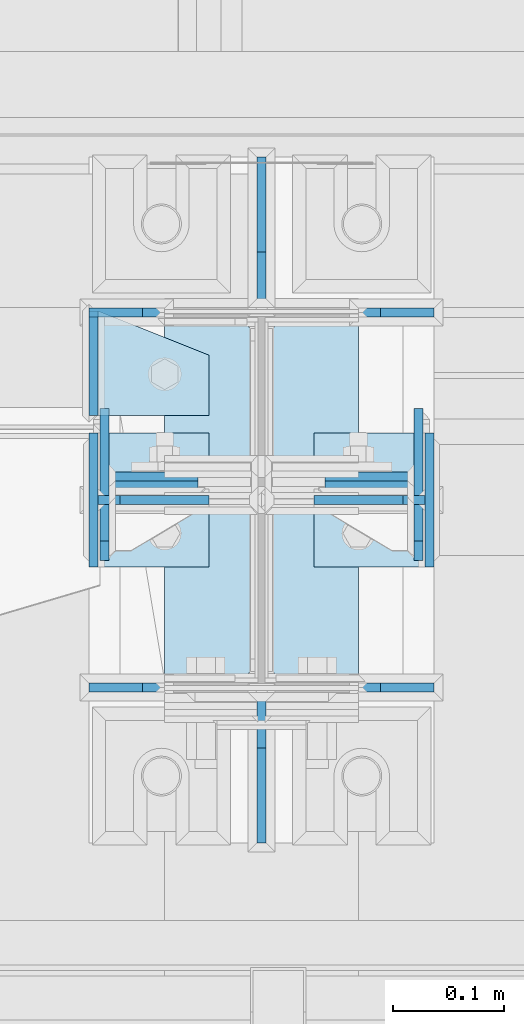
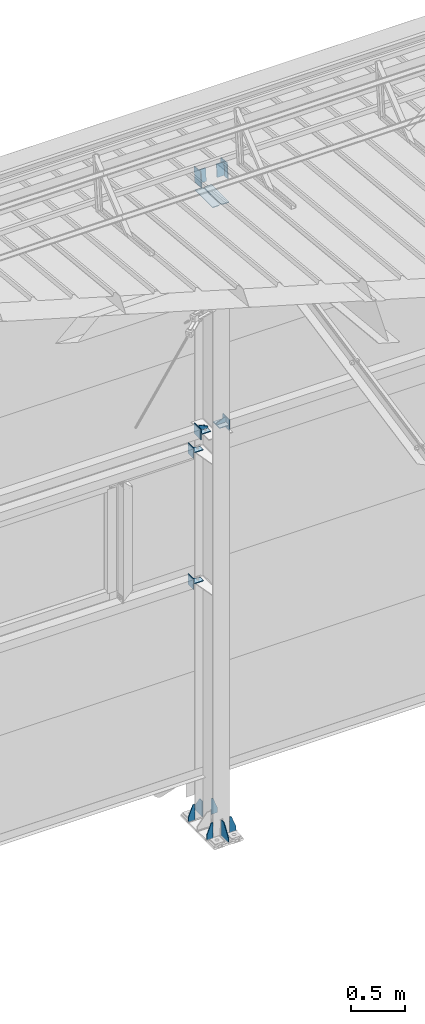
# One storey, part 136 of 709: 22 plates, 7 elements without a shape of their own.
"""IFC4 building model written with IfcOpenShell, lengths in millimetres."""

from ifc_helpers import new_model, si_unit, direction, frame, origin_with_axes, place, context, subcontext, project, spatial, line, indexed_curve, outline, extrude, material, element, aggregate, save


model = new_model("IFC4")

# Units and contexts
model_context = context("Model", 3, precision=0.2, world=origin_with_axes(), true_north=direction((0.0, 1.0)))
body_context = subcontext(model_context, "Body", "Model", "MODEL_VIEW")
ifc_project = project(units=[si_unit("LENGTHUNIT", "METRE", prefix="MILLI"), si_unit("AREAUNIT", "SQUARE_METRE"), si_unit("VOLUMEUNIT", "CUBIC_METRE"), si_unit("MASSUNIT", "GRAM", prefix="KILO"), si_unit("TIMEUNIT", "SECOND"), si_unit("PLANEANGLEUNIT", "RADIAN"), si_unit("SOLIDANGLEUNIT", "STERADIAN"), si_unit("THERMODYNAMICTEMPERATUREUNIT", "DEGREE_CELSIUS"), si_unit("LUMINOUSINTENSITYUNIT", "LUMEN")], contexts=[model_context])

# Site, building, storey
site_placement = place(None, origin_with_axes())
site = spatial("IfcSite", under=ifc_project, at=site_placement, CompositionType="ELEMENT")
building_placement = place(site_placement, origin_with_axes())
building = spatial("IfcBuilding", under=site, at=building_placement, Name="Undefined", CompositionType="ELEMENT")
storey_placement = place(building_placement, origin_with_axes())
storey = spatial("IfcBuildingStorey", under=building, at=storey_placement, Name="Undefined", CompositionType="ELEMENT", Elevation=0.0)

# Assembly, plates
assembly_1_placement = place(storey_placement, frame((10000.0, 21827.0, -200.0), z_axis=(-1.0, 0.0, 0.0), x_axis=(0.0, 0.0, 1.0)))
assembly_1 = element("IfcElementAssembly", 1, at=assembly_1_placement, inside=storey)
ifc_material = material(Name="C355-6", Category="STEEL")
plate_1_placement = place(assembly_1_placement, frame((25.0, -168.5, 87.0), z_axis=(0.0, 1.0, 0.0), x_axis=(0.0, 0.0, 1.0)))
plate_1 = element("IfcPlate", 2, at=plate_1_placement, material=ifc_material, ObjectType="419", context=body_context, shape_type="SolidModel", body=[
    extrude(outline(indexed_curve([(0.0, 0.0), (68.0, 0.0), (68.0, 50.0), (20.0, 175.0), (0.0, 175.0)], segments=[line(1, 2, 3, 4, 5, 1)])), frame((0.0, 0.0, 4.0), z_axis=(0.0, 0.0, 1.0), x_axis=(1.0, 0.0, 0.0)), (0.0, 0.0, -1.0), 8.0),
])
plate_2_placement = place(assembly_1_placement, frame((25.0, 168.5, -87.0), z_axis=(0.0, -1.0, 0.0), x_axis=(0.0, 0.0, -1.0)))
plate_2 = element("IfcPlate", 3, at=plate_2_placement, material=ifc_material, ObjectType="419", context=body_context, shape_type="SolidModel", body=[
    extrude(outline(indexed_curve([(0.0, 0.0), (68.0, 0.0), (68.0, 50.0), (20.0, 175.0), (0.0, 175.0)], segments=[line(1, 2, 3, 4, 5, 1)])), frame((0.0, 0.0, 4.0), z_axis=(0.0, 0.0, 1.0), x_axis=(1.0, 0.0, 0.0)), (0.0, 0.0, -1.0), 8.0),
])
plate_3_placement = place(assembly_1_placement, frame((25.0, 168.5, 87.0), z_axis=(0.0, 1.0, 0.0), x_axis=(0.0, 0.0, 1.0)))
plate_3 = element("IfcPlate", 4, at=plate_3_placement, material=ifc_material, ObjectType="419", context=body_context, shape_type="SolidModel", body=[
    extrude(outline(indexed_curve([(0.0, 0.0), (68.0, 0.0), (68.0, 50.0), (20.0, 175.0), (0.0, 175.0)], segments=[line(1, 2, 3, 4, 5, 1)])), frame((0.0, 0.0, 4.0), z_axis=(0.0, 0.0, 1.0), x_axis=(1.0, 0.0, 0.0)), (0.0, 0.0, -1.0), 8.0),
])
plate_4_placement = place(assembly_1_placement, frame((25.0, -168.5, -87.0), z_axis=(0.0, -1.0, 0.0), x_axis=(0.0, 0.0, -1.0)))
plate_4 = element("IfcPlate", 5, at=plate_4_placement, material=ifc_material, ObjectType="419", context=body_context, shape_type="SolidModel", body=[
    extrude(outline(indexed_curve([(0.0, 0.0), (68.0, 0.0), (68.0, 50.0), (20.0, 175.0), (0.0, 175.0)], segments=[line(1, 2, 3, 4, 5, 1)])), frame((0.0, 0.0, 4.0), z_axis=(0.0, 0.0, 1.0), x_axis=(1.0, 0.0, 0.0)), (0.0, 0.0, -1.0), 8.0),
])
plate_5_placement = place(assembly_1_placement, frame((25.0, -173.0, 0.0), z_axis=(0.0, 0.0, 1.0), x_axis=(0.0, -1.0, 0.0)))
plate_5 = element("IfcPlate", 6, at=plate_5_placement, material=ifc_material, ObjectType="418", context=body_context, shape_type="SolidModel", body=[
    extrude(outline(indexed_curve([(0.0, 0.0), (135.0, 0.0), (135.0, 50.0), (50.0, 175.0), (0.0, 175.0)], segments=[line(1, 2, 3, 4, 5, 1)])), frame((0.0, 0.0, 4.0), z_axis=(0.0, 0.0, 1.0), x_axis=(1.0, 0.0, 0.0)), (0.0, 0.0, -1.0), 8.0),
])
plate_6_placement = place(assembly_1_placement, frame((25.0, 173.0, 0.0), z_axis=(0.0, 0.0, -1.0), x_axis=(0.0, 1.0, 0.0)))
plate_6 = element("IfcPlate", 7, at=plate_6_placement, material=ifc_material, ObjectType="418", context=body_context, shape_type="SolidModel", body=[
    extrude(outline(indexed_curve([(0.0, 0.0), (135.0, 0.0), (135.0, 50.0), (50.0, 175.0), (0.0, 175.0)], segments=[line(1, 2, 3, 4, 5, 1)])), frame((0.0, 0.0, 4.0), z_axis=(0.0, 0.0, 1.0), x_axis=(1.0, 0.0, 0.0)), (0.0, 0.0, -1.0), 8.0),
])
plate_7_placement = place(assembly_1_placement, frame((7097.93718, -163.0, -87.0), z_axis=(-1.0, 0.0, 0.0), x_axis=(0.0, 0.0, 1.0)))
plate_7 = element("IfcPlate", 8, at=plate_7_placement, material=ifc_material, ObjectType="461", context=body_context, shape_type="SolidModel", body=[
    extrude(outline(indexed_curve([(0.0, 0.0), (68.0, 0.0), (83.0, 15.0), (83.0, 311.0), (68.0, 326.0), (0.0, 326.0)], segments=[line(1, 2, 3, 4, 5, 6, 1)])), frame((0.0, 0.0, 4.0), z_axis=(0.0, 0.0, 1.0), x_axis=(1.0, 0.0, 0.0)), (0.0, 0.0, -1.0), 8.0),
])
plate_8_placement = place(assembly_1_placement, frame((7097.93718, 163.0, 87.0), z_axis=(-1.0, 0.0, 0.0), x_axis=(0.0, 0.0, -1.0)))
plate_8 = element("IfcPlate", 9, at=plate_8_placement, material=ifc_material, ObjectType="461", context=body_context, shape_type="SolidModel", body=[
    extrude(outline(indexed_curve([(0.0, 0.0), (68.0, 0.0), (83.0, 15.0), (83.0, 311.0), (68.0, 326.0), (0.0, 326.0)], segments=[line(1, 2, 3, 4, 5, 6, 1)])), frame((0.0, 0.0, 4.0), z_axis=(0.0, 0.0, 1.0), x_axis=(1.0, 0.0, 0.0)), (0.0, 0.0, -1.0), 8.0),
])
aggregate(assembly_1, [plate_1, plate_2, plate_3, plate_4, plate_5, plate_6, plate_7, plate_8])

assembly_2_placement = place(storey_placement, frame((16000.0, 21827.0, 4310.0), z_axis=(0.0, 0.0, -1.0), x_axis=(-1.0, 0.0, 0.0)))
assembly_2 = element("IfcElementAssembly", 10, at=assembly_2_placement, inside=storey)
plate_9_placement = place(assembly_2_placement, frame((5953.0, -60.0, 0.0), z_axis=(0.0, 0.0, 1.0), x_axis=(0.0, 1.0, 0.0)))
plate_9 = element("IfcPlate", 11, at=plate_9_placement, material=ifc_material, ObjectType="507", context=body_context, shape_type="SolidModel", body=[
    extrude(outline(indexed_curve([(0.0, 0.0), (120.0, 0.0), (120.0, 100.0), (0.0, 100.0)], segments=[line(1, 2, 3, 4, 1)])), frame((0.0, 0.0, 4.0), z_axis=(0.0, 0.0, 1.0), x_axis=(1.0, 0.0, 0.0)), (0.0, 0.0, -1.0), 8.0),
])
plate_10_placement = place(assembly_2_placement, frame((5849.0, -60.0, 60.0), z_axis=(1.0, 0.0, 0.0), x_axis=(0.0, 0.0, -1.0)))
plate_10 = element("IfcPlate", 12, at=plate_10_placement, material=ifc_material, ObjectType="506", context=body_context, shape_type="SolidModel", body=[
    extrude(outline(indexed_curve([(0.0, 0.0), (120.0, 0.0), (120.0, 120.0), (0.0, 120.0)], segments=[line(1, 2, 3, 4, 1)])), frame((0.0, 0.0, 4.0), z_axis=(0.0, 0.0, 1.0), x_axis=(1.0, 0.0, 0.0)), (0.0, 0.0, -1.0), 8.0),
])
plate_11_placement = place(assembly_2_placement, frame((5953.0, 0.0, -60.0), z_axis=(0.0, -1.0, 0.0), x_axis=(0.0, 0.0, 1.0)))
plate_11 = element("IfcPlate", 13, at=plate_11_placement, material=ifc_material, ObjectType="508", context=body_context, shape_type="SolidModel", body=[
    extrude(outline(indexed_curve([(0.0, 80.0), (36.0, 0.0), (56.0, 0.0), (56.0, 90.0), (46.0, 100.0), (0.0, 100.0)], segments=[line(1, 2, 3, 4, 5, 6, 1)])), frame((0.0, 0.0, 4.0), z_axis=(0.0, 0.0, 1.0), x_axis=(1.0, 0.0, 0.0)), (0.0, 0.0, -1.0), 8.0),
])
aggregate(assembly_2, [plate_9, plate_10, plate_11])

assembly_3_placement = place(storey_placement, frame((10000.0, 21950.0, 2550.0), z_axis=(0.0, 0.0, -1.0), x_axis=(-1.0, 0.0, 0.0)))
assembly_3 = element("IfcElementAssembly", 14, at=assembly_3_placement, inside=storey)
plate_12_placement = place(assembly_3_placement, frame((47.0, 47.0, 0.0), z_axis=(0.0, 0.0, 1.0), x_axis=(0.0, -1.0, 0.0)))
plate_12 = element("IfcPlate", 15, at=plate_12_placement, material=ifc_material, ObjectType="502", context=body_context, shape_type="SolidModel", body=[
    extrude(outline(indexed_curve([(0.0, 100.0), (40.0, 0.0), (94.0, 0.0), (94.0, 100.0), (0.0, 100.0)], segments=[line(1, 2, 3, 4, 5, 1)])), frame((0.0, 0.0, 4.0), z_axis=(0.0, 0.0, 1.0), x_axis=(1.0, 0.0, 0.0)), (0.0, 0.0, -1.0), 8.0),
])
plate_13_placement = place(assembly_3_placement, frame((151.0, 47.0, -60.0), z_axis=(-1.0, 0.0, 0.0), x_axis=(0.0, -1.0, 0.0)))
plate_13 = element("IfcPlate", 16, at=plate_13_placement, material=ifc_material, ObjectType="501", context=body_context, shape_type="SolidModel", body=[
    extrude(outline(indexed_curve([(0.0, 0.0), (94.0, 0.0), (94.0, 120.0), (0.0, 120.0)], segments=[line(1, 2, 3, 4, 1)])), frame((0.0, 0.0, 4.0), z_axis=(0.0, 0.0, 1.0), x_axis=(1.0, 0.0, 0.0)), (0.0, 0.0, -1.0), 8.0),
])
aggregate(assembly_3, [plate_12, plate_13])

assembly_4_placement = place(storey_placement, frame((10000.0, 21950.0, 4020.0), z_axis=(0.0, 0.0, -1.0), x_axis=(-1.0, 0.0, 0.0)))
assembly_4 = element("IfcElementAssembly", 17, at=assembly_4_placement, inside=storey)
plate_14_placement = place(assembly_4_placement, frame((151.0, 47.0, -60.0), z_axis=(-1.0, 0.0, 0.0), x_axis=(0.0, -1.0, 0.0)))
plate_14 = element("IfcPlate", 18, at=plate_14_placement, material=ifc_material, ObjectType="501", context=body_context, shape_type="SolidModel", body=[
    extrude(outline(indexed_curve([(0.0, 0.0), (94.0, 0.0), (94.0, 120.0), (0.0, 120.0)], segments=[line(1, 2, 3, 4, 1)])), frame((0.0, 0.0, 4.0), z_axis=(0.0, 0.0, 1.0), x_axis=(1.0, 0.0, 0.0)), (0.0, 0.0, -1.0), 8.0),
])
plate_15_placement = place(assembly_4_placement, frame((47.0, 47.0, 0.0), z_axis=(0.0, 0.0, 1.0), x_axis=(0.0, -1.0, 0.0)))
plate_15 = element("IfcPlate", 19, at=plate_15_placement, material=ifc_material, ObjectType="502", context=body_context, shape_type="SolidModel", body=[
    extrude(outline(indexed_curve([(0.0, 100.0), (40.0, 0.0), (94.0, 0.0), (94.0, 100.0), (0.0, 100.0)], segments=[line(1, 2, 3, 4, 5, 1)])), frame((0.0, 0.0, 4.0), z_axis=(0.0, 0.0, 1.0), x_axis=(1.0, 0.0, 0.0)), (0.0, 0.0, -1.0), 8.0),
])
aggregate(assembly_4, [plate_14, plate_15])

assembly_5_placement = place(storey_placement, frame((10000.0, 21827.0, 4310.0), z_axis=(0.0, 0.0, -1.0), x_axis=(-1.0, 0.0, 0.0)))
assembly_5 = element("IfcElementAssembly", 20, at=assembly_5_placement, inside=storey)
plate_16_placement = place(assembly_5_placement, frame((47.0, 0.0, -60.0), z_axis=(0.0, 1.0, 0.0), x_axis=(0.0, 0.0, 1.0)))
plate_16 = element("IfcPlate", 21, at=plate_16_placement, material=ifc_material, ObjectType="508", context=body_context, shape_type="SolidModel", body=[
    extrude(outline(indexed_curve([(0.0, 80.0), (36.0, 0.0), (56.0, 0.0), (56.0, 90.0), (46.0, 100.0), (0.0, 100.0)], segments=[line(1, 2, 3, 4, 5, 6, 1)])), frame((0.0, 0.0, 4.0), z_axis=(0.0, 0.0, 1.0), x_axis=(1.0, 0.0, 0.0)), (0.0, 0.0, -1.0), 8.0),
])
plate_17_placement = place(assembly_5_placement, frame((47.0, 60.0, 0.0), z_axis=(0.0, 0.0, 1.0), x_axis=(0.0, -1.0, 0.0)))
plate_17 = element("IfcPlate", 22, at=plate_17_placement, material=ifc_material, ObjectType="507", context=body_context, shape_type="SolidModel", body=[
    extrude(outline(indexed_curve([(0.0, 0.0), (120.0, 0.0), (120.0, 100.0), (0.0, 100.0)], segments=[line(1, 2, 3, 4, 1)])), frame((0.0, 0.0, 4.0), z_axis=(0.0, 0.0, 1.0), x_axis=(1.0, 0.0, 0.0)), (0.0, 0.0, -1.0), 8.0),
])
plate_18_placement = place(assembly_5_placement, frame((151.0, 60.0, 60.0), z_axis=(-1.0, 0.0, 0.0), x_axis=(0.0, 0.0, -1.0)))
plate_18 = element("IfcPlate", 23, at=plate_18_placement, material=ifc_material, ObjectType="506", context=body_context, shape_type="SolidModel", body=[
    extrude(outline(indexed_curve([(0.0, 0.0), (120.0, 0.0), (120.0, 120.0), (0.0, 120.0)], segments=[line(1, 2, 3, 4, 1)])), frame((0.0, 0.0, 4.0), z_axis=(0.0, 0.0, 1.0), x_axis=(1.0, 0.0, 0.0)), (0.0, 0.0, -1.0), 8.0),
])
aggregate(assembly_5, [plate_16, plate_17, plate_18])

assembly_6_placement = place(storey_placement, frame((10000.0, 21841.04467, 7154.40952), z_axis=(0.0, -0.9950371902, 0.099503719), x_axis=(-1.0, 0.0, 0.0)))
assembly_6 = element("IfcElementAssembly", 24, at=assembly_6_placement, inside=storey)
plate_19_placement = place(assembly_6_placement, frame((57.0, -72.0, 0.0), z_axis=(0.0, 0.0, 1.0), x_axis=(1.0, 0.0, 0.0)))
plate_19 = element("IfcPlate", 25, at=plate_19_placement, material=ifc_material, ObjectType="597", context=body_context, shape_type="SolidModel", body=[
    extrude(outline(indexed_curve([(0.0, 0.0), (80.0, 0.0), (80.0, 144.0), (0.0, 144.0)], segments=[line(1, 2, 3, 4, 1)])), frame((0.0, 0.0, 4.0), z_axis=(0.0, 0.0, 1.0), x_axis=(1.0, 0.0, 0.0)), (0.0, 0.0, -1.0), 8.0),
])
plate_20_placement = place(assembly_6_placement, frame((141.0, -87.0, -60.0), z_axis=(-1.0, 0.0, 0.0), x_axis=(0.0, 0.0, 1.0)))
plate_20 = element("IfcPlate", 26, at=plate_20_placement, material=ifc_material, ObjectType="596", context=body_context, shape_type="SolidModel", body=[
    extrude(outline(indexed_curve([(0.0, 0.0), (120.0, 0.0), (120.0, 174.0), (0.0, 174.0)], segments=[line(1, 2, 3, 4, 1)])), frame((0.0, 0.0, 4.0), z_axis=(0.0, 0.0, 1.0), x_axis=(1.0, 0.0, 0.0)), (0.0, 0.0, -1.0), 8.0),
])
aggregate(assembly_6, [plate_19, plate_20])

assembly_7_placement = place(storey_placement, frame((16000.0, 21841.04467, 7154.40952), z_axis=(0.0, -0.9950371902, 0.099503719), x_axis=(-1.0, 0.0, 0.0)))
assembly_7 = element("IfcElementAssembly", 27, at=assembly_7_placement, inside=storey)
plate_21_placement = place(assembly_7_placement, frame((5859.0, -87.0, 60.0), z_axis=(1.0, 0.0, 0.0), x_axis=(0.0, 0.0, -1.0)))
plate_21 = element("IfcPlate", 28, at=plate_21_placement, material=ifc_material, ObjectType="596", context=body_context, shape_type="SolidModel", body=[
    extrude(outline(indexed_curve([(0.0, 0.0), (120.0, 0.0), (120.0, 174.0), (0.0, 174.0)], segments=[line(1, 2, 3, 4, 1)])), frame((0.0, 0.0, 4.0), z_axis=(0.0, 0.0, 1.0), x_axis=(1.0, 0.0, 0.0)), (0.0, 0.0, -1.0), 8.0),
])
plate_22_placement = place(assembly_7_placement, frame((5943.0, 72.0, 0.0), z_axis=(0.0, 0.0, 1.0), x_axis=(-1.0, 0.0, 0.0)))
plate_22 = element("IfcPlate", 29, at=plate_22_placement, material=ifc_material, ObjectType="597", context=body_context, shape_type="SolidModel", body=[
    extrude(outline(indexed_curve([(0.0, 0.0), (80.0, 0.0), (80.0, 144.0), (0.0, 144.0)], segments=[line(1, 2, 3, 4, 1)])), frame((0.0, 0.0, 4.0), z_axis=(0.0, 0.0, 1.0), x_axis=(1.0, 0.0, 0.0)), (0.0, 0.0, -1.0), 8.0),
])
aggregate(assembly_7, [plate_21, plate_22])

save(model, "model.ifc")
